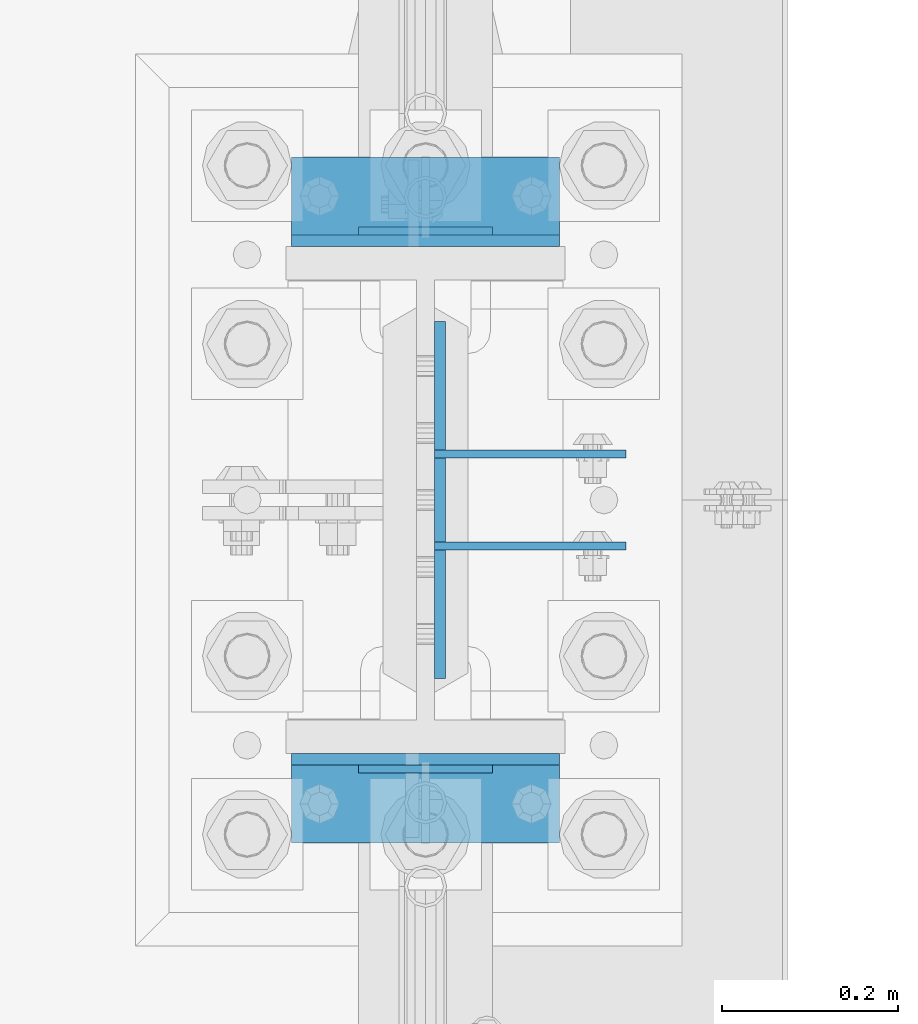
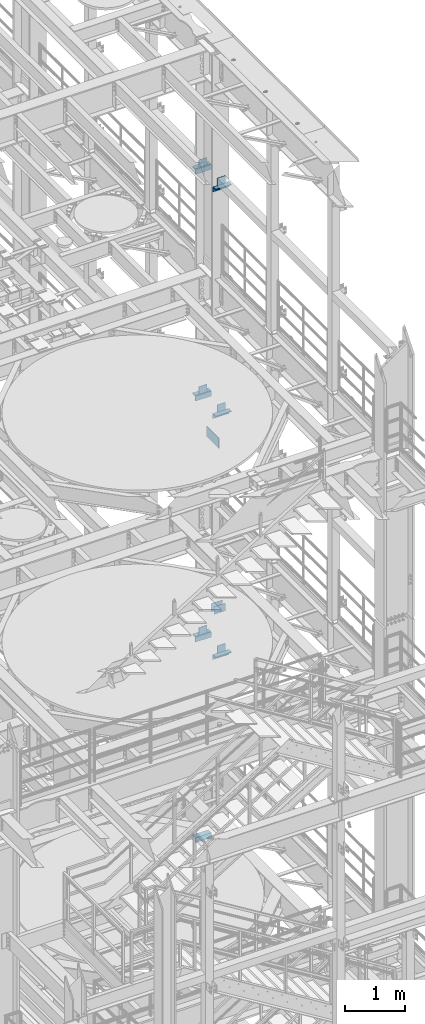
# One storey, part 1272 of 1876: 22 beams, 8 elements without a shape of their own.
"""IFC2X3 building model written with IfcOpenShell, lengths in millimetres."""

from ifc_helpers import new_model, si_unit, frame, origin_with_axes, place, context, subcontext, project, spatial, faceted_brep, material, type_object, element, aggregate, save


model = new_model("IFC2X3")

# Units and contexts
model_context = context("Model", 3, precision=1e-05, world=origin_with_axes())
body_context = subcontext(model_context, "Body", "Model", "MODEL_VIEW")
ifc_project = project(units=[si_unit("LENGTHUNIT", "METRE", prefix="MILLI"), si_unit("AREAUNIT", "SQUARE_METRE"), si_unit("VOLUMEUNIT", "CUBIC_METRE"), si_unit("MASSUNIT", "GRAM", prefix="KILO"), si_unit("TIMEUNIT", "SECOND"), si_unit("PLANEANGLEUNIT", "RADIAN"), si_unit("SOLIDANGLEUNIT", "STERADIAN"), si_unit("THERMODYNAMICTEMPERATUREUNIT", "DEGREE_CELSIUS"), si_unit("LUMINOUSINTENSITYUNIT", "LUMEN")], contexts=[model_context])

# Site, building, storey
site_placement = place(None, origin_with_axes())
site = spatial("IfcSite", under=ifc_project, at=site_placement, CompositionType="ELEMENT")
building_placement = place(site_placement, origin_with_axes())
building = spatial("IfcBuilding", under=site, at=building_placement, Name="Undefined", CompositionType="ELEMENT")
storey_placement = place(building_placement, origin_with_axes())
storey = spatial("IfcBuildingStorey", under=building, at=storey_placement, Name="Undefined", CompositionType="ELEMENT", Elevation=0.0)

# Assembly, beams
assembly_1_placement = place(storey_placement, origin_with_axes())
assembly_1 = element("IfcElementAssembly", 1, at=assembly_1_placement, inside=storey, Name="COLUMN", AssemblyPlace="NOTDEFINED", PredefinedType="RIGID_FRAME")
ifc_material_1 = material(Name="STEEL/A36")
beam_type_1 = type_object("IfcBeamType", PredefinedType="NOTDEFINED")
beam_1_placement = place(assembly_1_placement, frame((7630.31875, 1576.38750076294, 11029.95), z_axis=(0.0, 0.0, -1.0), x_axis=(1.0, 0.0, 0.0)))
beam_1 = element("IfcBeam", 2, at=beam_1_placement, type_object=beam_type_1, material=ifc_material_1, Name="PLATE", context=body_context, shape_type="Brep", body=[
    faceted_brep([(0.0, 4.76249999999982, -76.1999999999998), (3.63797880709171e-12, 4.76249999999982, 76.1999969482422), (218.28125, 4.76250000000005, 76.2000000000007), (218.28125, 4.76250000000005, -76.2000000000007), (3.63797880709171e-12, -4.76249999999982, 76.1999969482422), (218.28125, -4.76250000000005, 76.2000000000007), (0.0, -4.76249999999982, -76.1999999999998), (218.28125, -4.76250000000005, -76.2000000000007)], [[[0, 1, 2, 3]], [[1, 4, 5, 2]], [[4, 6, 7, 5]], [[6, 0, 3, 7]], [[5, 7, 3, 2]], [[6, 4, 1, 0]]]),
])
beam_2_placement = place(assembly_1_placement, frame((7630.31875, 1471.61250076294, 11029.95), z_axis=(0.0, 0.0, -1.0), x_axis=(1.0, 0.0, 0.0)))
beam_2 = element("IfcBeam", 3, at=beam_2_placement, type_object=beam_type_1, material=ifc_material_1, Name="PLATE", context=body_context, shape_type="Brep", body=[
    faceted_brep([(0.0, 4.76249999999982, -76.1999999999998), (3.63797880709171e-12, 4.76249999999982, 76.1999969482422), (218.28125, 4.76250000000005, 76.2000000000007), (218.28125, 4.76250000000005, -76.2000000000007), (3.63797880709171e-12, -4.76249999999982, 76.1999969482422), (218.28125, -4.76250000000005, 76.2000000000007), (0.0, -4.76249999999982, -76.1999999999998), (218.28125, -4.76250000000005, -76.2000000000007)], [[[0, 1, 2, 3]], [[1, 4, 5, 2]], [[4, 6, 7, 5]], [[6, 0, 3, 7]], [[5, 7, 3, 2]], [[6, 4, 1, 0]]]),
])

# Assembly, beam
assembly_2_placement = place(storey_placement, origin_with_axes())
assembly_2 = element("IfcElementAssembly", 4, at=assembly_2_placement, inside=storey, Name="BEAM", AssemblyPlace="NOTDEFINED", PredefinedType="RIGID_FRAME")
beam_3_placement = place(assembly_2_placement, frame((7696.2, 1217.6125, 19958.05), z_axis=(0.0, 0.0, -1.0), x_axis=(-1.0, 0.0, 0.0)))
beam_3 = element("IfcBeam", 5, at=beam_3_placement, type_object=beam_type_1, material=ifc_material_1, Name="PLATE", context=body_context, shape_type="Brep", body=[
    faceted_brep([(0.0, 4.76249999999982, -76.1999999999998), (3.63797880709171e-12, 4.76249999999982, 76.1999969482422), (152.399993896484, 4.76250000000073, 76.1999969482422), (152.4, 4.76249999999982, -76.1999999999998), (3.63797880709171e-12, -4.76249999999982, 76.1999969482422), (152.399993896484, -4.76250000000073, 76.1999969482422), (0.0, -4.76249999999982, -76.1999999999998), (152.4, -4.76249999999982, -76.1999999999998)], [[[0, 1, 2, 3]], [[4, 5, 2, 1]], [[4, 6, 7, 5]], [[6, 0, 3, 7]], [[5, 7, 3, 2]], [[6, 4, 1, 0]]]),
])

assembly_3_placement = place(storey_placement, origin_with_axes())
assembly_3 = element("IfcElementAssembly", 6, at=assembly_3_placement, inside=storey, Name="BEAM", AssemblyPlace="NOTDEFINED", PredefinedType="RIGID_FRAME")
beam_4_placement = place(assembly_3_placement, frame((7696.2, 1830.3875, 19958.05), z_axis=(0.0, 0.0, 1.0), x_axis=(-1.0, 0.0, 0.0)))
beam_4 = element("IfcBeam", 7, at=beam_4_placement, type_object=beam_type_1, material=ifc_material_1, Name="PLATE", context=body_context, shape_type="Brep", body=[
    faceted_brep([(0.0, 4.76249999999982, -76.1999999999998), (3.63797880709171e-12, 4.76249999999982, 76.1999969482422), (152.399993896484, 4.76250000000073, 76.1999969482422), (152.4, 4.76249999999982, -76.1999999999998), (3.63797880709171e-12, -4.76249999999982, 76.1999969482422), (152.399993896484, -4.76250000000073, 76.1999969482422), (0.0, -4.76249999999982, -76.1999999999998), (152.4, -4.76249999999982, -76.1999999999998)], [[[0, 1, 2, 3]], [[4, 5, 2, 1]], [[4, 6, 7, 5]], [[6, 0, 3, 7]], [[5, 7, 3, 2]], [[6, 4, 1, 0]]]),
])

assembly_4_placement = place(storey_placement, origin_with_axes())
assembly_4 = element("IfcElementAssembly", 8, at=assembly_4_placement, inside=storey, Name="BEAM", AssemblyPlace="NOTDEFINED", PredefinedType="RIGID_FRAME")
beam_5_placement = place(assembly_4_placement, frame((7696.2, 1217.6125, 15335.25), z_axis=(0.0, 0.0, -1.0), x_axis=(-1.0, 0.0, 0.0)))
beam_5 = element("IfcBeam", 9, at=beam_5_placement, type_object=beam_type_1, material=ifc_material_1, Name="PLATE", context=body_context, shape_type="Brep", body=[
    faceted_brep([(0.0, 4.76249999999982, -76.1999999999998), (3.63797880709171e-12, 4.76249999999982, 76.1999969482422), (152.399993896484, 4.76250000000073, 76.1999969482422), (152.4, 4.76249999999982, -76.1999999999998), (3.63797880709171e-12, -4.76249999999982, 76.1999969482422), (152.399993896484, -4.76250000000073, 76.1999969482422), (0.0, -4.76249999999982, -76.1999999999998), (152.4, -4.76249999999982, -76.1999999999998)], [[[0, 1, 2, 3]], [[4, 5, 2, 1]], [[4, 6, 7, 5]], [[6, 0, 3, 7]], [[5, 7, 3, 2]], [[6, 4, 1, 0]]]),
])

assembly_5_placement = place(storey_placement, origin_with_axes())
assembly_5 = element("IfcElementAssembly", 10, at=assembly_5_placement, inside=storey, Name="BEAM", AssemblyPlace="NOTDEFINED", PredefinedType="RIGID_FRAME")
beam_6_placement = place(assembly_5_placement, frame((7696.2, 1830.3875, 15335.25), z_axis=(0.0, 0.0, 1.0), x_axis=(-1.0, 0.0, 0.0)))
beam_6 = element("IfcBeam", 11, at=beam_6_placement, type_object=beam_type_1, material=ifc_material_1, Name="PLATE", context=body_context, shape_type="Brep", body=[
    faceted_brep([(0.0, 4.76249999999982, -76.1999999999998), (3.63797880709171e-12, 4.76249999999982, 76.1999969482422), (152.399993896484, 4.76250000000073, 76.1999969482422), (152.4, 4.76249999999982, -76.1999999999998), (3.63797880709171e-12, -4.76249999999982, 76.1999969482422), (152.399993896484, -4.76250000000073, 76.1999969482422), (0.0, -4.76249999999982, -76.1999999999998), (152.4, -4.76249999999982, -76.1999999999998)], [[[0, 1, 2, 3]], [[4, 5, 2, 1]], [[4, 6, 7, 5]], [[6, 0, 3, 7]], [[5, 7, 3, 2]], [[6, 4, 1, 0]]]),
])

assembly_6_placement = place(storey_placement, origin_with_axes())
assembly_6 = element("IfcElementAssembly", 12, at=assembly_6_placement, inside=storey, Name="BEAM", AssemblyPlace="NOTDEFINED", PredefinedType="RIGID_FRAME")
beam_7_placement = place(assembly_6_placement, frame((7696.2, 1217.6125, 10420.35), z_axis=(0.0, 0.0, -1.0), x_axis=(-1.0, 0.0, 0.0)))
beam_7 = element("IfcBeam", 13, at=beam_7_placement, type_object=beam_type_1, material=ifc_material_1, Name="PLATE", context=body_context, shape_type="Brep", body=[
    faceted_brep([(0.0, 4.76249999999982, -76.1999999999998), (3.63797880709171e-12, 4.76249999999982, 76.1999969482422), (152.399993896484, 4.76250000000073, 76.1999969482422), (152.4, 4.76249999999982, -76.1999999999998), (3.63797880709171e-12, -4.76249999999982, 76.1999969482422), (152.399993896484, -4.76250000000073, 76.1999969482422), (0.0, -4.76249999999982, -76.1999999999998), (152.4, -4.76249999999982, -76.1999999999998)], [[[0, 1, 2, 3]], [[4, 5, 2, 1]], [[4, 6, 7, 5]], [[6, 0, 3, 7]], [[5, 7, 3, 2]], [[6, 4, 1, 0]]]),
])

assembly_7_placement = place(storey_placement, origin_with_axes())
assembly_7 = element("IfcElementAssembly", 14, at=assembly_7_placement, inside=storey, Name="BEAM", AssemblyPlace="NOTDEFINED", PredefinedType="RIGID_FRAME")
beam_8_placement = place(assembly_7_placement, frame((7696.2, 1830.3875, 10420.35), z_axis=(0.0, 0.0, 1.0), x_axis=(-1.0, 0.0, 0.0)))
beam_8 = element("IfcBeam", 15, at=beam_8_placement, type_object=beam_type_1, material=ifc_material_1, Name="PLATE", context=body_context, shape_type="Brep", body=[
    faceted_brep([(0.0, 4.76249999999982, -76.1999999999998), (3.63797880709171e-12, 4.76249999999982, 76.1999969482422), (152.399993896484, 4.76250000000073, 76.1999969482422), (152.4, 4.76249999999982, -76.1999999999998), (3.63797880709171e-12, -4.76249999999982, 76.1999969482422), (152.399993896484, -4.76250000000073, 76.1999969482422), (0.0, -4.76249999999982, -76.1999999999998), (152.4, -4.76249999999982, -76.1999999999998)], [[[0, 1, 2, 3]], [[4, 5, 2, 1]], [[4, 6, 7, 5]], [[6, 0, 3, 7]], [[5, 7, 3, 2]], [[6, 4, 1, 0]]]),
])

# Beam
beam_type_2 = type_object("IfcBeamType", PredefinedType="NOTDEFINED")
beam_9_placement = place(assembly_2_placement, frame((7467.6, 1177.925, 19877.0875), z_axis=(0.0, -1.0, 0.0), x_axis=(1.0, 0.0, 0.0)))
beam_9 = element("IfcBeam", 16, at=beam_9_placement, type_object=beam_type_2, material=ifc_material_1, Name="PLATE", context=body_context, shape_type="Brep", body=[
    faceted_brep([(0.0, 4.76250000000073, -44.4499999999998), (0.0, 4.76250000000073, 44.4499999999998), (304.799999999999, 4.76250000000073, 44.4499999999998), (304.799999999999, 4.76250000000073, -44.4499999999998), (0.0, -4.76250000000073, 44.4499999999998), (304.799999999999, -4.76250000000073, 44.4499999999998), (0.0, -4.76250000000073, -44.4499999999998), (304.799999999999, -4.76250000000073, -44.4499999999998)], [[[0, 1, 2, 3]], [[1, 4, 5, 2]], [[4, 6, 7, 5]], [[6, 0, 3, 7]], [[5, 7, 3, 2]], [[6, 4, 1, 0]]]),
])

aggregate(assembly_2, [beam_3, beam_9])

beam_10_placement = place(assembly_3_placement, frame((7467.6, 1870.075, 19877.0875), z_axis=(0.0, 1.0, 0.0), x_axis=(1.0, 0.0, 0.0)))
beam_10 = element("IfcBeam", 17, at=beam_10_placement, type_object=beam_type_2, material=ifc_material_1, Name="PLATE", context=body_context, shape_type="Brep", body=[
    faceted_brep([(0.0, 4.76250000000073, -44.4499999999998), (0.0, 4.76250000000073, 44.4499999999998), (304.799999999999, 4.76250000000073, 44.4499999999998), (304.799999999999, 4.76250000000073, -44.4499999999998), (0.0, -4.76250000000073, 44.4499999999998), (304.799999999999, -4.76250000000073, 44.4499999999998), (0.0, -4.76250000000073, -44.4499999999998), (304.799999999999, -4.76250000000073, -44.4499999999998)], [[[0, 1, 2, 3]], [[1, 4, 5, 2]], [[4, 6, 7, 5]], [[6, 0, 3, 7]], [[5, 7, 3, 2]], [[6, 4, 1, 0]]]),
])

aggregate(assembly_3, [beam_4, beam_10])

beam_11_placement = place(assembly_4_placement, frame((7467.6, 1177.925, 15254.2875), z_axis=(0.0, -1.0, 0.0), x_axis=(1.0, 0.0, 0.0)))
beam_11 = element("IfcBeam", 18, at=beam_11_placement, type_object=beam_type_2, material=ifc_material_1, Name="PLATE", context=body_context, shape_type="Brep", body=[
    faceted_brep([(0.0, 4.76250000000073, -44.4499999999998), (0.0, 4.76250000000073, 44.4499999999998), (304.799999999999, 4.76250000000073, 44.4499999999998), (304.799999999999, 4.76250000000073, -44.4499999999998), (0.0, -4.76250000000073, 44.4499999999998), (304.799999999999, -4.76250000000073, 44.4499999999998), (0.0, -4.76250000000073, -44.4499999999998), (304.799999999999, -4.76250000000073, -44.4499999999998)], [[[0, 1, 2, 3]], [[1, 4, 5, 2]], [[4, 6, 7, 5]], [[6, 0, 3, 7]], [[5, 7, 3, 2]], [[6, 4, 1, 0]]]),
])

aggregate(assembly_4, [beam_5, beam_11])

beam_12_placement = place(assembly_5_placement, frame((7467.6, 1870.075, 15254.2875), z_axis=(0.0, 1.0, 0.0), x_axis=(1.0, 0.0, 0.0)))
beam_12 = element("IfcBeam", 19, at=beam_12_placement, type_object=beam_type_2, material=ifc_material_1, Name="PLATE", context=body_context, shape_type="Brep", body=[
    faceted_brep([(0.0, 4.76250000000073, -44.4499999999998), (0.0, 4.76250000000073, 44.4499999999998), (304.799999999999, 4.76250000000073, 44.4499999999998), (304.799999999999, 4.76250000000073, -44.4499999999998), (0.0, -4.76250000000073, 44.4499999999998), (304.799999999999, -4.76250000000073, 44.4499999999998), (0.0, -4.76250000000073, -44.4499999999998), (304.799999999999, -4.76250000000073, -44.4499999999998)], [[[0, 1, 2, 3]], [[1, 4, 5, 2]], [[4, 6, 7, 5]], [[6, 0, 3, 7]], [[5, 7, 3, 2]], [[6, 4, 1, 0]]]),
])

aggregate(assembly_5, [beam_6, beam_12])

beam_13_placement = place(assembly_6_placement, frame((7467.6, 1177.925, 10339.3875), z_axis=(0.0, -1.0, 0.0), x_axis=(1.0, 0.0, 0.0)))
beam_13 = element("IfcBeam", 20, at=beam_13_placement, type_object=beam_type_2, material=ifc_material_1, Name="PLATE", context=body_context, shape_type="Brep", body=[
    faceted_brep([(0.0, 4.76250000000073, -44.4499999999998), (0.0, 4.76250000000073, 44.4499999999998), (304.799999999999, 4.76250000000073, 44.4499999999998), (304.799999999999, 4.76250000000073, -44.4499999999998), (0.0, -4.76250000000073, 44.4499999999998), (304.799999999999, -4.76250000000073, 44.4499999999998), (0.0, -4.76250000000073, -44.4499999999998), (304.799999999999, -4.76250000000073, -44.4499999999998)], [[[0, 1, 2, 3]], [[1, 4, 5, 2]], [[4, 6, 7, 5]], [[6, 0, 3, 7]], [[5, 7, 3, 2]], [[6, 4, 1, 0]]]),
])

aggregate(assembly_6, [beam_7, beam_13])

beam_14_placement = place(assembly_7_placement, frame((7467.6, 1870.075, 10339.3875), z_axis=(0.0, 1.0, 0.0), x_axis=(1.0, 0.0, 0.0)))
beam_14 = element("IfcBeam", 21, at=beam_14_placement, type_object=beam_type_2, material=ifc_material_1, Name="PLATE", context=body_context, shape_type="Brep", body=[
    faceted_brep([(0.0, 4.76250000000073, -44.4499999999998), (0.0, 4.76250000000073, 44.4499999999998), (304.799999999999, 4.76250000000073, 44.4499999999998), (304.799999999999, 4.76250000000073, -44.4499999999998), (0.0, -4.76250000000073, 44.4499999999998), (304.799999999999, -4.76250000000073, 44.4499999999998), (0.0, -4.76250000000073, -44.4499999999998), (304.799999999999, -4.76250000000073, -44.4499999999998)], [[[0, 1, 2, 3]], [[1, 4, 5, 2]], [[4, 6, 7, 5]], [[6, 0, 3, 7]], [[5, 7, 3, 2]], [[6, 4, 1, 0]]]),
])

aggregate(assembly_7, [beam_8, beam_14])

# Assembly, beams
assembly_8_placement = place(storey_placement, origin_with_axes())
assembly_8 = element("IfcElementAssembly", 22, at=assembly_8_placement, inside=storey, Name="COLUMN", AssemblyPlace="NOTDEFINED", PredefinedType="RIGID_FRAME")
beam_type_3 = type_object("IfcBeamType", Name="L4X4X3/8", PredefinedType="NOTDEFINED")
beam_15_placement = place(assembly_8_placement, frame((7467.6, 1184.275, 19821.525), z_axis=(0.0, -1.0, 0.0), x_axis=(1.0, 0.0, 0.0)))
beam_15 = element("IfcBeam", 23, at=beam_15_placement, type_object=beam_type_3, material=ifc_material_1, Name="ANGLE", ObjectType="L4X4X3/8", context=body_context, shape_type="Brep", body=[
    faceted_brep([(0.0, 50.7999999999993, -50.8000000000002), (0.0, 50.7999999999993, 50.8000000000002), (304.799999999999, 50.7999999999993, 50.8000000000002), (304.799999999999, 50.7999999999993, -50.8000000000002), (0.0, 41.2750000000015, 50.8000000000002), (304.799999999999, 41.2750000000015, 50.8000000000002), (0.0, 41.2750000000015, -41.2749999999996), (304.799999999999, 41.2750000000015, -41.2749999999996), (0.0, -50.7999999999993, -41.2749999999996), (304.799999999999, -50.7999999999993, -41.2749999999996), (0.0, -50.7999999999993, -50.8000000000002), (304.799999999999, -50.7999999999993, -50.8000000000002)], [[[0, 1, 2, 3]], [[1, 4, 5, 2]], [[4, 6, 7, 5]], [[6, 8, 9, 7]], [[8, 10, 11, 9]], [[10, 0, 3, 11]], [[5, 7, 9, 11, 3, 2]], [[10, 8, 6, 4, 1, 0]]]),
])
beam_16_placement = place(assembly_8_placement, frame((7772.4, 1863.725, 19821.525), z_axis=(0.0, 1.0, 0.0), x_axis=(-1.0, 0.0, 0.0)))
beam_16 = element("IfcBeam", 24, at=beam_16_placement, type_object=beam_type_3, material=ifc_material_1, Name="ANGLE", ObjectType="L4X4X3/8", context=body_context, shape_type="Brep", body=[
    faceted_brep([(0.0, 50.7999999999993, -50.8000000000002), (0.0, 50.7999999999993, 50.8000000000002), (304.799999999999, 50.7999999999993, 50.8000000000002), (304.799999999999, 50.7999999999993, -50.8000000000002), (0.0, 41.2750000000015, 50.8000000000002), (304.799999999999, 41.2750000000015, 50.8000000000002), (0.0, 41.2750000000015, -41.2749999999996), (304.799999999999, 41.2750000000015, -41.2749999999996), (0.0, -50.7999999999993, -41.2749999999996), (304.799999999999, -50.7999999999993, -41.2749999999996), (0.0, -50.7999999999993, -50.8000000000002), (304.799999999999, -50.7999999999993, -50.8000000000002)], [[[0, 1, 2, 3]], [[1, 4, 5, 2]], [[4, 6, 7, 5]], [[6, 8, 9, 7]], [[8, 10, 11, 9]], [[10, 0, 3, 11]], [[5, 7, 9, 11, 3, 2]], [[10, 8, 6, 4, 1, 0]]]),
])
beam_17_placement = place(assembly_8_placement, frame((7467.6, 1184.275, 15198.725), z_axis=(0.0, -1.0, 0.0), x_axis=(1.0, 0.0, 0.0)))
beam_17 = element("IfcBeam", 25, at=beam_17_placement, type_object=beam_type_3, material=ifc_material_1, Name="ANGLE", ObjectType="L4X4X3/8", context=body_context, shape_type="Brep", body=[
    faceted_brep([(0.0, 50.7999999999993, -50.8000000000002), (0.0, 50.7999999999993, 50.8000000000002), (304.799999999999, 50.7999999999993, 50.8000000000002), (304.799999999999, 50.7999999999993, -50.8000000000002), (0.0, 41.2750000000015, 50.8000000000002), (304.799999999999, 41.2750000000015, 50.8000000000002), (0.0, 41.2750000000015, -41.2749999999996), (304.799999999999, 41.2750000000015, -41.2749999999996), (0.0, -50.7999999999993, -41.2749999999996), (304.799999999999, -50.7999999999993, -41.2749999999996), (0.0, -50.7999999999993, -50.8000000000002), (304.799999999999, -50.7999999999993, -50.8000000000002)], [[[0, 1, 2, 3]], [[1, 4, 5, 2]], [[4, 6, 7, 5]], [[6, 8, 9, 7]], [[8, 10, 11, 9]], [[10, 0, 3, 11]], [[5, 7, 9, 11, 3, 2]], [[10, 8, 6, 4, 1, 0]]]),
])
beam_18_placement = place(assembly_8_placement, frame((7772.4, 1863.725, 15198.725), z_axis=(0.0, 1.0, 0.0), x_axis=(-1.0, 0.0, 0.0)))
beam_18 = element("IfcBeam", 26, at=beam_18_placement, type_object=beam_type_3, material=ifc_material_1, Name="ANGLE", ObjectType="L4X4X3/8", context=body_context, shape_type="Brep", body=[
    faceted_brep([(0.0, 50.7999999999993, -50.8000000000002), (0.0, 50.7999999999993, 50.8000000000002), (304.799999999999, 50.7999999999993, 50.8000000000002), (304.799999999999, 50.7999999999993, -50.8000000000002), (0.0, 41.2750000000015, 50.8000000000002), (304.799999999999, 41.2750000000015, 50.8000000000002), (0.0, 41.2750000000015, -41.2749999999996), (304.799999999999, 41.2750000000015, -41.2749999999996), (0.0, -50.7999999999993, -41.2749999999996), (304.799999999999, -50.7999999999993, -41.2749999999996), (0.0, -50.7999999999993, -50.8000000000002), (304.799999999999, -50.7999999999993, -50.8000000000002)], [[[0, 1, 2, 3]], [[1, 4, 5, 2]], [[4, 6, 7, 5]], [[6, 8, 9, 7]], [[8, 10, 11, 9]], [[10, 0, 3, 11]], [[5, 7, 9, 11, 3, 2]], [[10, 8, 6, 4, 1, 0]]]),
])
aggregate(assembly_8, [beam_15, beam_16, beam_17, beam_18])

# Beam
beam_19_placement = place(assembly_1_placement, frame((7467.6, 1184.275, 10283.825), z_axis=(0.0, -1.0, 0.0), x_axis=(1.0, 0.0, 0.0)))
beam_19 = element("IfcBeam", 27, at=beam_19_placement, type_object=beam_type_3, material=ifc_material_1, Name="ANGLE", ObjectType="L4X4X3/8", context=body_context, shape_type="Brep", body=[
    faceted_brep([(0.0, 50.7999999999993, -50.8000000000002), (0.0, 50.7999999999993, 50.8000000000002), (304.799999999999, 50.7999999999993, 50.8000000000002), (304.799999999999, 50.7999999999993, -50.8000000000002), (0.0, 41.2750000000015, 50.8000000000002), (304.799999999999, 41.2750000000015, 50.8000000000002), (0.0, 41.2750000000015, -41.2749999999996), (304.799999999999, 41.2750000000015, -41.2749999999996), (0.0, -50.7999999999993, -41.2749999999996), (304.799999999999, -50.7999999999993, -41.2749999999996), (0.0, -50.7999999999993, -50.8000000000002), (304.799999999999, -50.7999999999993, -50.8000000000002)], [[[0, 1, 2, 3]], [[1, 4, 5, 2]], [[4, 6, 7, 5]], [[6, 8, 9, 7]], [[8, 10, 11, 9]], [[10, 0, 3, 11]], [[5, 7, 9, 11, 3, 2]], [[10, 8, 6, 4, 1, 0]]]),
])

beam_20_placement = place(assembly_1_placement, frame((7772.4, 1863.725, 10283.825), z_axis=(0.0, 1.0, 0.0), x_axis=(-1.0, 0.0, 0.0)))
beam_20 = element("IfcBeam", 28, at=beam_20_placement, type_object=beam_type_3, material=ifc_material_1, Name="ANGLE", ObjectType="L4X4X3/8", context=body_context, shape_type="Brep", body=[
    faceted_brep([(0.0, 50.7999999999993, -50.8000000000002), (0.0, 50.7999999999993, 50.8000000000002), (304.799999999999, 50.7999999999993, 50.8000000000002), (304.799999999999, 50.7999999999993, -50.8000000000002), (0.0, 41.2750000000015, 50.8000000000002), (304.799999999999, 41.2750000000015, 50.8000000000002), (0.0, 41.2750000000015, -41.2749999999996), (304.799999999999, 41.2750000000015, -41.2749999999996), (0.0, -50.7999999999993, -41.2749999999996), (304.799999999999, -50.7999999999993, -41.2749999999996), (0.0, -50.7999999999993, -50.8000000000002), (304.799999999999, -50.7999999999993, -50.8000000000002)], [[[0, 1, 2, 3]], [[1, 4, 5, 2]], [[4, 6, 7, 5]], [[6, 8, 9, 7]], [[8, 10, 11, 9]], [[10, 0, 3, 11]], [[5, 7, 9, 11, 3, 2]], [[10, 8, 6, 4, 1, 0]]]),
])

beam_21_placement = place(assembly_1_placement, frame((7772.4, 1863.725, 6194.425), z_axis=(0.0, 1.0, 0.0), x_axis=(-1.0, 0.0, 0.0)))
beam_21 = element("IfcBeam", 29, at=beam_21_placement, type_object=beam_type_3, material=ifc_material_1, Name="ANGLE", ObjectType="L4X4X3/8", context=body_context, shape_type="Brep", body=[
    faceted_brep([(0.0, 50.7999999999993, -50.8000000000002), (0.0, 50.7999999999993, 50.8000000000002), (304.799999999999, 50.7999999999993, 50.8000000000002), (304.799999999999, 50.7999999999993, -50.8000000000002), (0.0, 41.2750000000015, 50.8000000000002), (304.799999999999, 41.2750000000015, 50.8000000000002), (0.0, 41.2750000000015, -41.2749999999996), (304.799999999999, 41.2750000000015, -41.2749999999996), (0.0, -50.7999999999993, -41.2749999999996), (304.799999999999, -50.7999999999993, -41.2749999999996), (0.0, -50.7999999999993, -50.8000000000002), (304.799999999999, -50.7999999999993, -50.8000000000002)], [[[0, 1, 2, 3]], [[1, 4, 5, 2]], [[4, 6, 7, 5]], [[6, 8, 9, 7]], [[8, 10, 11, 9]], [[10, 0, 3, 11]], [[5, 7, 9, 11, 3, 2]], [[10, 8, 6, 4, 1, 0]]]),
])

ifc_material_2 = material(Name="STEEL/A572-50")
beam_type_4 = type_object("IfcBeamType", PredefinedType="NOTDEFINED")
beam_22_placement = place(assembly_1_placement, frame((7636.66875, 1524.0, 14636.75), z_axis=(0.0, 1.0, 0.0), x_axis=(0.0, 0.0, -1.0)))
beam_22 = element("IfcBeam", 30, at=beam_22_placement, type_object=beam_type_4, material=ifc_material_2, Name="PLATE", context=body_context, shape_type="Brep", body=[
    faceted_brep([(0.0, 6.35000000000036, -203.2), (0.0, 6.35000000000036, 203.2), (209.550000000001, 6.35000000000036, 203.2), (209.550000000001, 6.35000000000036, -203.2), (0.0, -6.35000000000036, 203.2), (209.550000000001, -6.35000000000036, 203.2), (0.0, -6.35000000000036, -203.2), (209.550000000001, -6.35000000000036, -203.2)], [[[0, 1, 2, 3]], [[1, 4, 5, 2]], [[4, 6, 7, 5]], [[6, 0, 3, 7]], [[5, 7, 3, 2]], [[6, 4, 1, 0]]]),
])

aggregate(assembly_1, [beam_1, beam_2, beam_19, beam_20, beam_21, beam_22])

save(model, "model.ifc")
